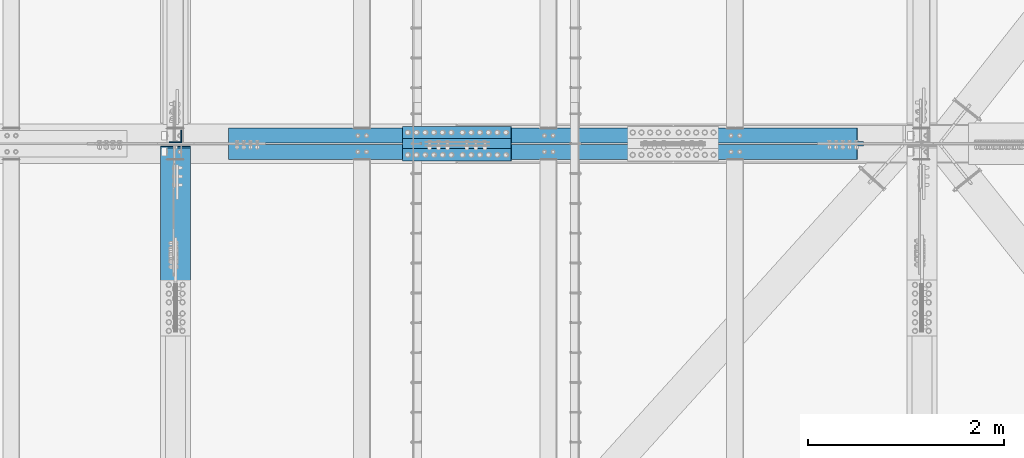
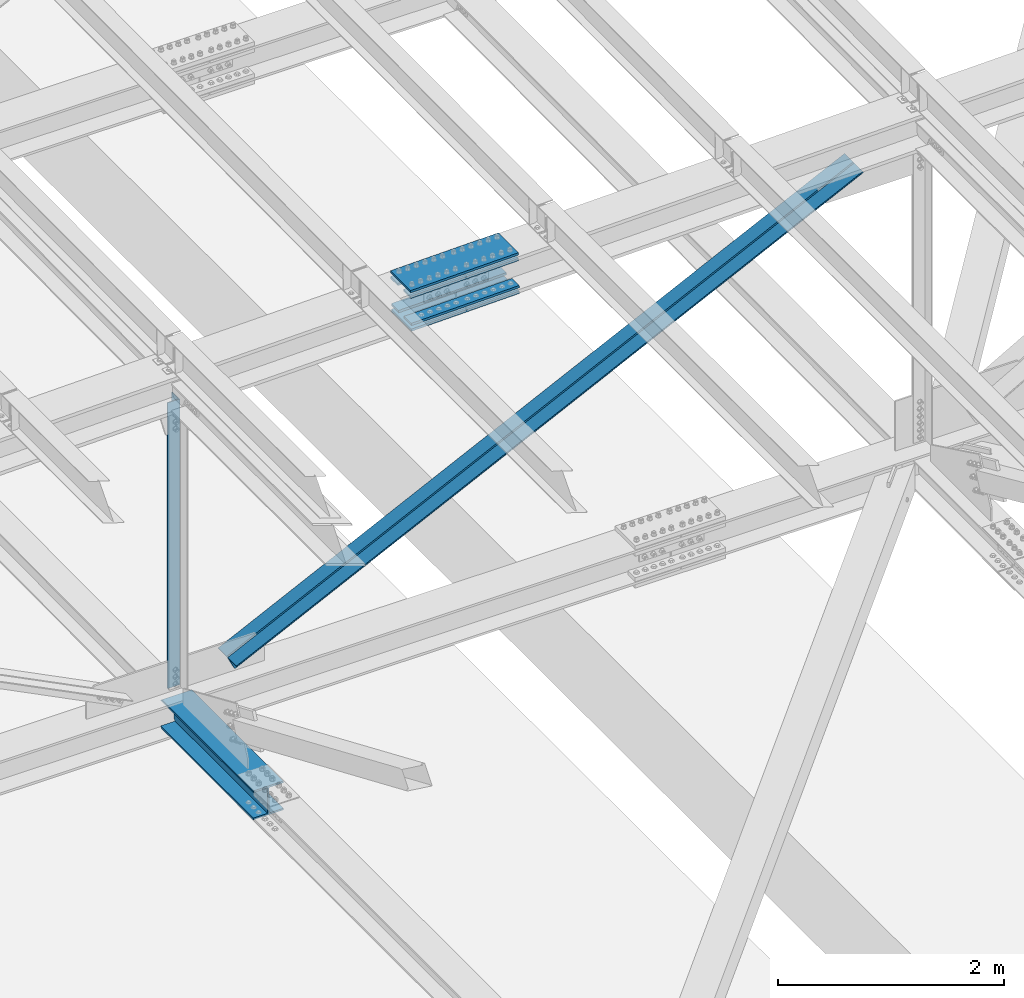
# One storey, part 1831 of 3843: 8 beams, 2 members, 5 elements without a shape of their own.
"""IFC2X3 building model written with IfcOpenShell, lengths in millimetres."""

from ifc_helpers import new_model, si_unit, frame, origin_with_axes, place, context, subcontext, project, spatial, faceted_brep, material, type_object, element, aggregate, save


model = new_model("IFC2X3")

# Units and contexts
model_context = context("Model", 3, precision=1e-05, world=origin_with_axes())
body_context = subcontext(model_context, "Body", "Model", "MODEL_VIEW")
ifc_project = project(units=[si_unit("LENGTHUNIT", "METRE", prefix="MILLI"), si_unit("AREAUNIT", "SQUARE_METRE"), si_unit("VOLUMEUNIT", "CUBIC_METRE"), si_unit("MASSUNIT", "GRAM", prefix="KILO"), si_unit("TIMEUNIT", "SECOND"), si_unit("PLANEANGLEUNIT", "RADIAN"), si_unit("SOLIDANGLEUNIT", "STERADIAN"), si_unit("THERMODYNAMICTEMPERATUREUNIT", "DEGREE_CELSIUS"), si_unit("LUMINOUSINTENSITYUNIT", "LUMEN")], contexts=[model_context])

# Site, building, storey
site_placement = place(None, origin_with_axes())
site = spatial("IfcSite", under=ifc_project, at=site_placement, CompositionType="ELEMENT")
building_placement = place(site_placement, origin_with_axes())
building = spatial("IfcBuilding", under=site, at=building_placement, Name="Undefined", CompositionType="ELEMENT")
storey_placement = place(building_placement, origin_with_axes())
storey = spatial("IfcBuildingStorey", under=building, at=storey_placement, Name="Undefined", CompositionType="ELEMENT", Elevation=0.0)

# Assembly, beam
assembly_1_placement = place(storey_placement, origin_with_axes())
assembly_1 = element("IfcElementAssembly", 1, at=assembly_1_placement, inside=storey, Name="BEAM", AssemblyPlace="NOTDEFINED", PredefinedType="RIGID_FRAME")
ifc_material_1 = material(Name="STEEL/A992")
beam_type_1 = type_object("IfcBeamType", Name="W12X79", PredefinedType="NOTDEFINED")
beam_1_placement = place(assembly_1_placement, frame((62636.3999999999, 32169.1000000061, 42256.5692807487), z_axis=(0.0, -0.00152891300032206, 0.999998831211836), x_axis=(0.0, 0.999998831211836, 0.00152891300031876)))
beam_1 = element("IfcBeam", 2, at=beam_1_placement, type_object=beam_type_1, material=ifc_material_1, Name="BEAM", ObjectType="W12X79", context=body_context, shape_type="Brep", body=[
    faceted_brep([(1656.79849716198, -6.34999999999854, -131.762499994948), (1669.49849716202, 6.34999999999854, -119.062499994892), (1669.49849716291, 6.34999999999854, 119.062500007327), (1656.79849716206, -6.34999999999854, 131.762500007273), (1650.44849716037, -6.34999999999854, -138.11249999659), (1650.44849716037, -153.987500000003, -138.11249999659), (1631.39849716191, -153.987500000003, -157.162499996637), (1631.39849716191, 153.987500000003, -157.162499996637), (1650.44849716037, 153.987500000003, -138.11249999659), (1650.44849716037, 6.34999999999854, -138.11249999659), (6.34999999578577, -153.987500000003, 157.162499999627), (6.34999999578577, -153.987500000003, 138.112499999675), (1650.44849716586, -153.987500000003, 138.112500003459), (1631.39849716211, -153.987500000003, 157.162500003418), (6.34999999578577, 153.987500000003, 157.162499999627), (1631.39849716211, 153.987500000003, 157.162500003418), (6.34999999578577, 153.987500000003, 138.112499999675), (1650.44849716586, 153.987500000003, 138.112500003459), (6.34999999578577, 6.34999999999854, 138.112499999675), (1650.44849716586, 6.34999999999854, 138.112500003459), (6.34999999578577, -153.987500000003, -157.162499999562), (6.34999999578577, -153.987500000003, -138.11249999961), (6.34999999578577, -6.34999999999854, -138.11249999961), (6.34999999578577, -6.34999999999854, 138.112499999675), (6.34999999578577, 6.34999999999854, -138.11249999961), (6.34999999578577, 153.987500000003, -138.11249999961), (6.34999999578577, 153.987500000003, -157.162499999562), (1650.44849716586, -6.34999999999854, 138.112500003459)], [[[0, 1, 2, 3]], [[4, 5, 6, 7, 8, 9, 1, 0]], [[10, 11, 12, 13]], [[14, 10, 13, 15]], [[16, 14, 15, 17]], [[18, 16, 17, 19]], [[20, 21, 22, 23, 11, 10, 14, 16, 18, 24, 25, 26]], [[11, 23, 27, 12]], [[19, 17, 15, 13, 12, 27, 3, 2]], [[24, 18, 19, 2, 1, 9]], [[25, 24, 9, 8]], [[26, 25, 8, 7]], [[20, 26, 7, 6]], [[21, 20, 6, 5]], [[22, 21, 5, 4]], [[27, 23, 22, 4, 0, 3]]]),
])
aggregate(assembly_1, [beam_1])

# Assembly, beams
assembly_2_placement = place(storey_placement, origin_with_axes())
assembly_2 = element("IfcElementAssembly", 3, at=assembly_2_placement, inside=storey, Name="BEAM", AssemblyPlace="NOTDEFINED", PredefinedType="RIGID_FRAME")
ifc_material_2 = material(Name="STEEL/A572-50")
beam_type_2 = type_object("IfcBeamType", PredefinedType="NOTDEFINED")
beam_2_placement = place(assembly_2_placement, frame((64961.7320280687, 33731.2, 45688.0546417747), z_axis=(0.0, 1.0, 0.0), x_axis=(0.999765952267441, 0.0, 0.0216342480057898)))
beam_2 = element("IfcBeam", 4, at=beam_2_placement, type_object=beam_type_2, material=ifc_material_2, Name="PLATE", context=body_context, shape_type="Brep", body=[
    faceted_brep([(-4.36557456851006e-11, 12.7000000000116, -63.5), (-4.36557456851006e-11, 12.7000000000116, 63.5), (1104.90000001677, 12.7000000017251, 63.5), (1104.90000001677, 12.7000000017251, -63.5), (1.45519152283669e-11, -12.700000000008, 63.5), (1104.90000001682, -12.6999999982909, 63.5), (1.45519152283669e-11, -12.700000000008, -63.5), (1104.90000001682, -12.6999999982909, -63.5)], [[[0, 1, 2, 3]], [[1, 4, 5, 2]], [[4, 6, 7, 5]], [[6, 0, 3, 7]], [[5, 7, 3, 2]], [[6, 4, 1, 0]]]),
])
beam_3_placement = place(assembly_2_placement, frame((64955.3439752061, 33731.2, 45983.2605327964), z_axis=(0.0, 1.0, 0.0), x_axis=(0.999765952267441, 0.0, 0.0216342480057898)))
beam_3 = element("IfcBeam", 5, at=beam_3_placement, type_object=beam_type_2, material=ifc_material_2, Name="PLATE", context=body_context, shape_type="Brep", body=[
    faceted_brep([(-4.36557456851006e-11, 12.7000000000116, -63.5), (-4.36557456851006e-11, 12.7000000000116, 63.5), (1104.90000001677, 12.7000000017251, 63.5), (1104.90000001677, 12.7000000017251, -63.5), (1.45519152283669e-11, -12.700000000008, 63.5), (1104.90000001682, -12.6999999982909, 63.5), (1.45519152283669e-11, -12.700000000008, -63.5), (1104.90000001682, -12.6999999982909, -63.5)], [[[0, 1, 2, 3]], [[1, 4, 5, 2]], [[4, 6, 7, 5]], [[6, 0, 3, 7]], [[5, 7, 3, 2]], [[6, 4, 1, 0]]]),
])
beam_4_placement = place(assembly_2_placement, frame((64961.7320280687, 33959.8, 45688.0546417747), z_axis=(0.0, 1.0, 0.0), x_axis=(0.999765952267441, 0.0, 0.0216342480057898)))
beam_4 = element("IfcBeam", 6, at=beam_4_placement, type_object=beam_type_2, material=ifc_material_2, Name="PLATE", context=body_context, shape_type="Brep", body=[
    faceted_brep([(-4.36557456851006e-11, 12.7000000000116, -63.5), (-4.36557456851006e-11, 12.7000000000116, 63.5), (1104.90000001677, 12.7000000017251, 63.5), (1104.90000001677, 12.7000000017251, -63.5), (1.45519152283669e-11, -12.700000000008, 63.5), (1104.90000001682, -12.6999999982909, 63.5), (1.45519152283669e-11, -12.700000000008, -63.5), (1104.90000001682, -12.6999999982909, -63.5)], [[[0, 1, 2, 3]], [[1, 4, 5, 2]], [[4, 6, 7, 5]], [[6, 0, 3, 7]], [[5, 7, 3, 2]], [[6, 4, 1, 0]]]),
])
beam_5_placement = place(assembly_2_placement, frame((64955.3439752061, 33959.8, 45983.2605327964), z_axis=(0.0, 1.0, 0.0), x_axis=(0.999765952267441, 0.0, 0.0216342480057898)))
beam_5 = element("IfcBeam", 7, at=beam_5_placement, type_object=beam_type_2, material=ifc_material_2, Name="PLATE", context=body_context, shape_type="Brep", body=[
    faceted_brep([(-4.36557456851006e-11, 12.7000000000116, -63.5), (-4.36557456851006e-11, 12.7000000000116, 63.5), (1104.90000001677, 12.7000000017251, 63.5), (1104.90000001677, 12.7000000017251, -63.5), (1.45519152283669e-11, -12.700000000008, 63.5), (1104.90000001682, -12.6999999982909, 63.5), (1.45519152283669e-11, -12.700000000008, -63.5), (1104.90000001682, -12.6999999982909, -63.5)], [[[0, 1, 2, 3]], [[1, 4, 5, 2]], [[4, 6, 7, 5]], [[6, 0, 3, 7]], [[5, 7, 3, 2]], [[6, 4, 1, 0]]]),
])
beam_type_3 = type_object("IfcBeamType", PredefinedType="NOTDEFINED")
beam_6_placement = place(assembly_2_placement, frame((66067.7128594766, 33845.5, 45650.0603000223), z_axis=(0.0, 1.0, 0.0), x_axis=(-0.999765952267441, 0.0, -0.0216342480057875)))
beam_6 = element("IfcBeam", 8, at=beam_6_placement, type_object=beam_type_3, material=ifc_material_2, Name="PLATE", context=body_context, shape_type="Brep", body=[
    faceted_brep([(-1.45519152283669e-11, 12.7000000000025, -177.800000000003), (-1.45519152283669e-11, 12.7000000000025, 177.800000000003), (1104.90000001682, 12.7000000017051, 177.800000000003), (1104.90000001682, 12.7000000017051, -177.800000000003), (4.36557456851006e-11, -12.7000000000171, 177.800000000003), (1104.90000001686, -12.6999999983072, 177.800000000003), (4.36557456851006e-11, -12.7000000000171, -177.800000000003), (1104.90000001686, -12.6999999983072, -177.800000000003)], [[[0, 1, 2, 3]], [[1, 4, 5, 2]], [[4, 6, 7, 5]], [[6, 0, 3, 7]], [[5, 7, 3, 2]], [[6, 4, 1, 0]]]),
])
beam_7_placement = place(assembly_2_placement, frame((66058.6459454177, 33845.5, 46069.0622245766), z_axis=(0.0, 1.0, 0.0), x_axis=(-0.999765952267441, 0.0, -0.0216342480057875)))
beam_7 = element("IfcBeam", 9, at=beam_7_placement, type_object=beam_type_3, material=ifc_material_2, Name="PLATE", context=body_context, shape_type="Brep", body=[
    faceted_brep([(-1.45519152283669e-11, 12.7000000000025, -177.800000000003), (-1.45519152283669e-11, 12.7000000000025, 177.800000000003), (1104.90000001682, 12.7000000017051, 177.800000000003), (1104.90000001682, 12.7000000017051, -177.800000000003), (4.36557456851006e-11, -12.7000000000171, 177.800000000003), (1104.90000001686, -12.6999999983072, 177.800000000003), (4.36557456851006e-11, -12.7000000000171, -177.800000000003), (1104.90000001686, -12.6999999983072, -177.800000000003)], [[[0, 1, 2, 3]], [[1, 4, 5, 2]], [[4, 6, 7, 5]], [[6, 0, 3, 7]], [[5, 7, 3, 2]], [[6, 4, 1, 0]]]),
])
aggregate(assembly_2, [beam_2, beam_3, beam_4, beam_5, beam_6, beam_7])

# Assembly, beam
assembly_3_placement = place(storey_placement, origin_with_axes())
assembly_3 = element("IfcElementAssembly", 10, at=assembly_3_placement, inside=storey, Name="ANGLE", AssemblyPlace="NOTDEFINED", PredefinedType="RIGID_FRAME")
beam_type_4 = type_object("IfcBeamType", Name="L5X5X3/8", PredefinedType="NOTDEFINED")
beam_8_placement = place(assembly_3_placement, frame((62636.4, 33918.525, 45785.4081121488), z_axis=(-1.0, 0.0, 0.0), x_axis=(0.0, 0.0, -1.0)))
beam_8 = element("IfcBeam", 11, at=beam_8_placement, type_object=beam_type_4, material=ifc_material_2, Name="ANGLE", ObjectType="L5X5X3/8", context=body_context, shape_type="Brep", body=[
    faceted_brep([(223.676125720856, 63.5, -63.500000000713), (223.676125847858, 63.5, 63.499999999287), (3316.6377958123, 63.5, 63.4999999894062), (3316.6377958123, 63.5, -63.5000000105938), (223.676125847858, 53.9749999999985, 63.499999999287), (3316.6377958123, 53.9749999999985, 63.4999999894062), (223.676125730388, 53.9749999999985, -53.9750000007189), (3316.6377958123, 53.9749999999985, -53.9750000105923), (223.676125730388, -63.5, -53.9750000007189), (3316.6377958123, -63.5, -53.9750000105923), (223.676125720856, -63.5, -63.500000000713), (3316.6377958123, -63.5, -63.5000000105938)], [[[0, 1, 2, 3]], [[1, 4, 5, 2]], [[4, 6, 7, 5]], [[6, 8, 9, 7]], [[8, 10, 11, 9]], [[10, 0, 3, 11]], [[5, 7, 9, 11, 3, 2]], [[10, 8, 6, 4, 1, 0]]]),
])
aggregate(assembly_3, [beam_8])

# Assembly, member
assembly_4_placement = place(storey_placement, origin_with_axes())
assembly_4 = element("IfcElementAssembly", 12, at=assembly_4_placement, inside=storey, Name="ANGLE", AssemblyPlace="NOTDEFINED", PredefinedType="RIGID_FRAME")
member_type = type_object("IfcMemberType", Name="L6X6X1/2", PredefinedType="NOTDEFINED")
member_1_placement = place(assembly_4_placement, frame((70256.3999999752, 33931.225, 45950.2996849343), z_axis=(0.0, 1.0, 0.0), x_axis=(-0.89997067391171, 0.0, -0.435950439957231)))
member_1 = element("IfcMember", 13, at=member_1_placement, type_object=member_type, material=ifc_material_2, Name="ANGLE", ObjectType="L6X6X1/2", context=body_context, shape_type="Brep", body=[
    faceted_brep([(700.157648391585, 76.2000000021199, -76.1999999999971), (700.157648391585, 76.2000000021199, 76.1999999999971), (7827.75698675959, 76.200000021754, 76.1999999999971), (7827.75698675959, 76.200000021754, -76.1999999999971), (700.157648391498, 63.5000000020864, 76.1999999999971), (7827.7569867595, 63.5000000217169, 76.1999999999971), (700.157648391498, 63.5000000020864, -63.5), (7827.7569867595, 63.5000000217169, -63.5), (700.157648390581, -76.1999999982672, -63.5), (7827.7569867586, -76.1999999786331, -63.5), (700.157648390581, -76.1999999982672, -76.1999999999971), (7827.7569867586, -76.1999999786331, -76.1999999999971)], [[[0, 1, 2, 3]], [[1, 4, 5, 2]], [[4, 6, 7, 5]], [[6, 8, 9, 7]], [[8, 10, 11, 9]], [[10, 0, 3, 11]], [[5, 7, 9, 11, 3, 2]], [[10, 8, 6, 4, 1, 0]]]),
])
aggregate(assembly_4, [member_1])

assembly_5_placement = place(storey_placement, origin_with_axes())
assembly_5 = element("IfcElementAssembly", 14, at=assembly_5_placement, inside=storey, Name="ANGLE", AssemblyPlace="NOTDEFINED", PredefinedType="RIGID_FRAME")
member_2_placement = place(assembly_5_placement, frame((62636.4000003808, 33759.775, 42259.1323531697), z_axis=(0.0, -1.0, 0.0), x_axis=(0.899970673911709, 0.0, 0.435950439957233)))
member_2 = element("IfcMember", 15, at=member_2_placement, type_object=member_type, material=ifc_material_2, Name="ANGLE", ObjectType="L6X6X1/2", context=body_context, shape_type="Brep", body=[
    faceted_brep([(639.185570310525, 76.199999998189, -76.1999999999971), (639.185570310525, 76.199999998189, 76.1999999999971), (7766.78490867853, 76.1999999785585, 76.1999999999971), (7766.78490867853, 76.1999999785585, -76.1999999999971), (639.185570310525, 63.4999999981956, 76.1999999999971), (7766.78490867854, 63.499999978565, 76.1999999999971), (639.185570310525, 63.4999999981956, -63.5), (7766.78490867854, 63.499999978565, -63.5), (639.185570310525, -76.2000000017106, -63.5), (7766.78490867854, -76.2000000213447, -63.5), (639.185570310525, -76.2000000017106, -76.1999999999971), (7766.78490867854, -76.2000000213447, -76.1999999999971)], [[[0, 1, 2, 3]], [[1, 4, 5, 2]], [[4, 6, 7, 5]], [[6, 8, 9, 7]], [[8, 10, 11, 9]], [[10, 0, 3, 11]], [[5, 7, 9, 11, 3, 2]], [[10, 8, 6, 4, 1, 0]]]),
])
aggregate(assembly_5, [member_2])

save(model, "model.ifc")
